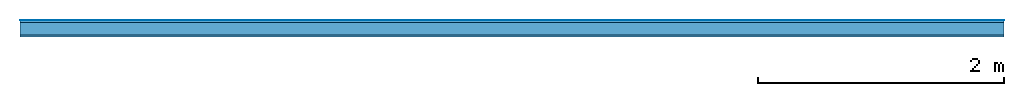
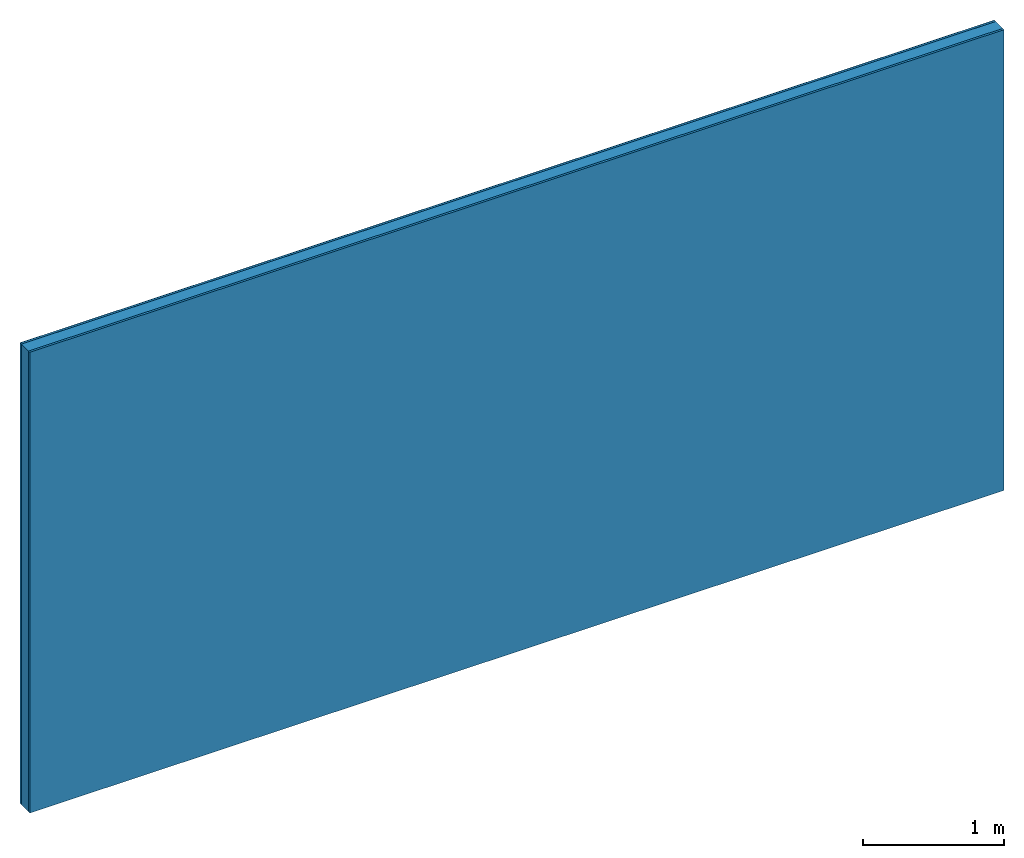
# One storey: 3 plates, 1 member, 1 element without a shape of its own.
"""IFC4 building model written with IfcOpenShell, lengths in metres."""

from ifc_helpers import new_model, si_unit, derived_unit, direction, frame, frame_2d, origin, origin_with_axes, place, context, project, spatial, rectangle, extrude, material, layer, layer_set, type_object, element, aggregate, save


model = new_model("IFC4")

# Units and contexts
plan_context = context("Plan", 3, precision=1e-05, world=origin(), true_north=direction((0.0, 1.0)))
model_context = context("Model", 3, precision=1e-05, world=origin(), true_north=direction((0.0, 1.0)))
ifc_project = project(units=[si_unit("LENGTHUNIT", "METRE"), derived_unit("SOUNDPRESSUREUNIT", [(si_unit("PRESSUREUNIT", "PASCAL", prefix="MICRO"), 0)]), si_unit("ENERGYUNIT", "JOULE", prefix="MEGA"), si_unit("MASSUNIT", "GRAM", prefix="KILO"), derived_unit("THERMALTRANSMITTANCEUNIT", [(si_unit("POWERUNIT", "WATT"), 1), (si_unit("AREAUNIT", "SQUARE_METRE"), -1), (si_unit("THERMODYNAMICTEMPERATUREUNIT", "KELVIN"), -1)]), derived_unit("AREADENSITYUNIT", [(si_unit("MASSUNIT", "GRAM", prefix="KILO"), 1), (si_unit("AREAUNIT", "SQUARE_METRE"), -1)]), derived_unit("USERDEFINED", [(si_unit("ENERGYUNIT", "JOULE", prefix="MEGA"), 1), (si_unit("AREAUNIT", "SQUARE_METRE"), -1)])], contexts=[plan_context, model_context])

# Site, building, storey
site = spatial("IfcSite", under=ifc_project)
building_placement = place(None, origin())
building = spatial("IfcBuilding", under=site, at=building_placement)
storey_placement = place(building_placement, origin())
storey = spatial("IfcBuildingStorey", under=building, at=storey_placement)

# Wall, member, plates
ifc_material_1 = material(Category="04.001")
ifc_layer_1 = layer(ifc_material_1, 0.003, Name="Surface")
ifc_material_2 = material(Category="03.007")
ifc_layer_2 = layer(ifc_material_2, 0.018, Name="1st layer")
ifc_material_3 = material(Name="of the art")
ifc_layer_3 = layer(ifc_material_3, 0.0, Name="Bond")
ifc_layer_4 = layer(None, 0.1, Name="Support")
ifc_layer_5 = layer(ifc_material_3, 0.0, Name="Bond")
ifc_layer_6 = layer(ifc_material_2, 0.018, Name="1st layer")
ifc_layer_set = layer_set([ifc_layer_1, ifc_layer_2, ifc_layer_3, ifc_layer_4, ifc_layer_5, ifc_layer_6])
wall_type = type_object("IfcWallType", Name="C0429", PredefinedType="NOTDEFINED", material=ifc_layer_set)
wall_placement = place(None, frame((0.0, 0.0, 0.0), z_axis=(0.0, -1.0, 0.0), x_axis=(1.0, 0.0, 0.0)))
wall = element("IfcWall", 1, at=wall_placement, inside=storey, type_object=wall_type, material=ifc_layer_set, Name="Wall #1")
ifc_material_4 = material(Name="Solid timber panel")
member_placement = place(wall_placement, origin())
member = element("IfcMember", 2, at=member_placement, material=ifc_material_4, Name="Support", context=plan_context, shape_type="SweptSolid", body=[
    extrude(rectangle(XDim=1.0, YDim=0.1, at=frame_2d((0.5, 0.05), x_axis=(1.0, 0.0))), frame((0.0, 4.0, 0.021), z_axis=(0.0, -1.0, 0.0), x_axis=(1.0, 0.0, 0.0)), (0.0, 0.0, 1.0), 4.0),
    extrude(rectangle(XDim=1.0, YDim=0.1, at=frame_2d((0.5, 0.05), x_axis=(1.0, 0.0))), frame((1.0, 4.0, 0.021), z_axis=(0.0, -1.0, 0.0), x_axis=(1.0, 0.0, 0.0)), (0.0, 0.0, 1.0), 4.0),
    extrude(rectangle(XDim=1.0, YDim=0.1, at=frame_2d((0.5, 0.05), x_axis=(1.0, 0.0))), frame((2.0, 4.0, 0.021), z_axis=(0.0, -1.0, 0.0), x_axis=(1.0, 0.0, 0.0)), (0.0, 0.0, 1.0), 4.0),
    extrude(rectangle(XDim=1.0, YDim=0.1, at=frame_2d((0.5, 0.05), x_axis=(1.0, 0.0))), frame((3.0, 4.0, 0.021), z_axis=(0.0, -1.0, 0.0), x_axis=(1.0, 0.0, 0.0)), (0.0, 0.0, 1.0), 4.0),
    extrude(rectangle(XDim=1.0, YDim=0.1, at=frame_2d((0.5, 0.05), x_axis=(1.0, 0.0))), frame((4.0, 4.0, 0.021), z_axis=(0.0, -1.0, 0.0), x_axis=(1.0, 0.0, 0.0)), (0.0, 0.0, 1.0), 4.0),
    extrude(rectangle(XDim=1.0, YDim=0.1, at=frame_2d((0.5, 0.05), x_axis=(1.0, 0.0))), frame((5.0, 4.0, 0.021), z_axis=(0.0, -1.0, 0.0), x_axis=(1.0, 0.0, 0.0)), (0.0, 0.0, 1.0), 4.0),
    extrude(rectangle(XDim=1.0, YDim=0.1, at=frame_2d((0.5, 0.05), x_axis=(1.0, 0.0))), frame((6.0, 4.0, 0.021), z_axis=(0.0, -1.0, 0.0), x_axis=(1.0, 0.0, 0.0)), (0.0, 0.0, 1.0), 4.0),
    extrude(rectangle(XDim=1.0, YDim=0.1, at=frame_2d((0.5, 0.05), x_axis=(1.0, 0.0))), frame((7.0, 4.0, 0.021), z_axis=(0.0, -1.0, 0.0), x_axis=(1.0, 0.0, 0.0)), (0.0, 0.0, 1.0), 4.0),
])
plate_1_placement = place(wall_placement, origin())
plate_1 = element("IfcPlate", 3, at=plate_1_placement, material=ifc_material_1, Name="Surface", context=plan_context, shape_type="SweptSolid", body=[
    extrude(rectangle(XDim=8.0, YDim=4.0, at=frame_2d((4.0, 2.0), x_axis=(1.0, 0.0))), origin_with_axes(), (0.0, 0.0, 1.0), 0.003),
])
plate_2_placement = place(wall_placement, origin())
plate_2 = element("IfcPlate", 4, at=plate_2_placement, material=ifc_material_2, Name="1st layer", context=plan_context, shape_type="SweptSolid", body=[
    extrude(rectangle(XDim=8.0, YDim=4.0, at=frame_2d((4.0, 2.0), x_axis=(1.0, 0.0))), frame((0.0, 0.0, 0.003), z_axis=(0.0, 0.0, 1.0), x_axis=(1.0, 0.0, 0.0)), (0.0, 0.0, 1.0), 0.018),
])
plate_3_placement = place(wall_placement, origin())
plate_3 = element("IfcPlate", 5, at=plate_3_placement, material=ifc_material_2, Name="1st layer", context=plan_context, shape_type="SweptSolid", body=[
    extrude(rectangle(XDim=8.0, YDim=4.0, at=frame_2d((4.0, 2.0), x_axis=(1.0, 0.0))), frame((0.0, 0.0, 0.121), z_axis=(0.0, 0.0, 1.0), x_axis=(1.0, 0.0, 0.0)), (0.0, 0.0, 1.0), 0.018),
])
aggregate(wall, [plate_1, plate_2, member, plate_3])

save(model, "model.ifc")
